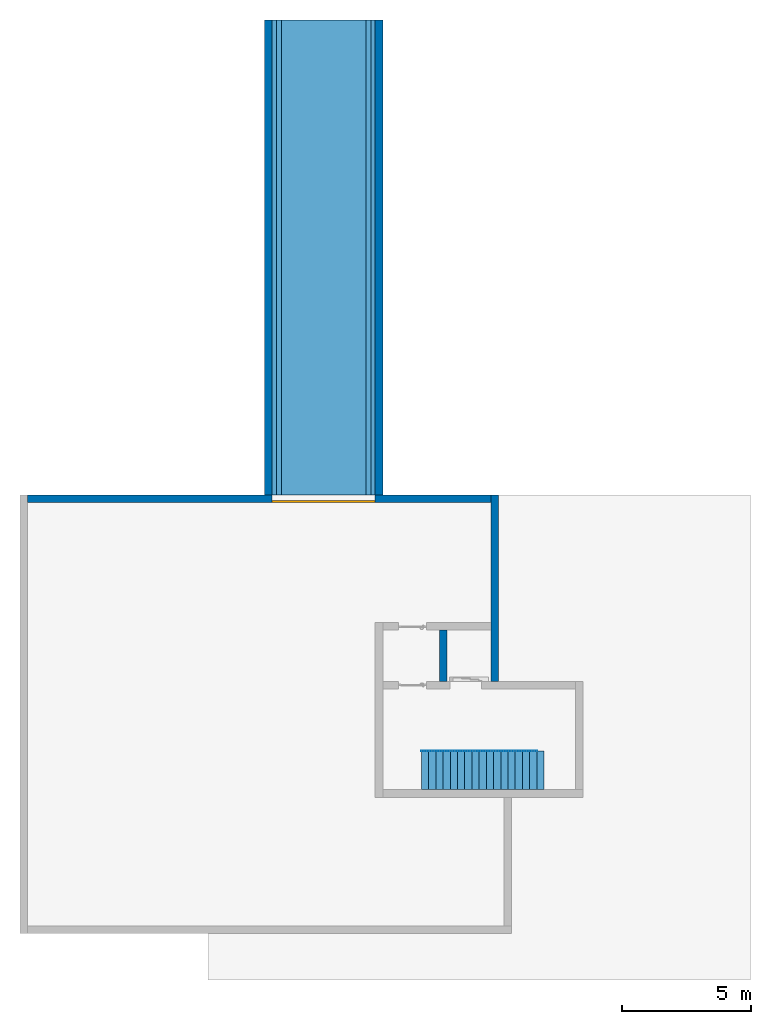
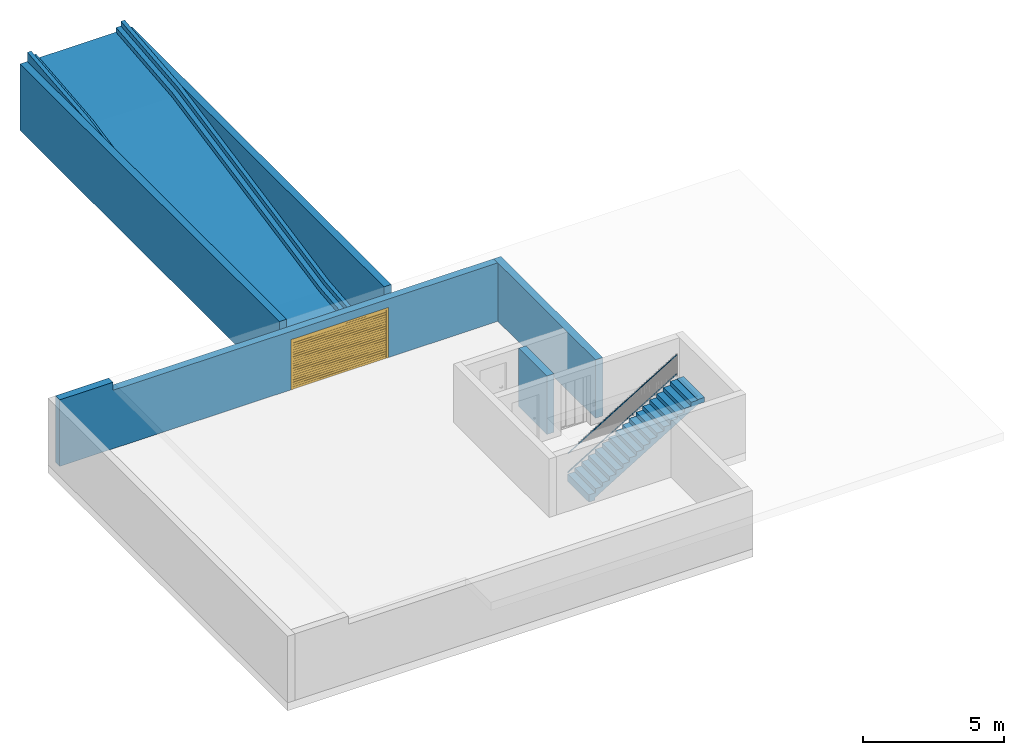
# One storey, part 5 of 6: 5 walls, 3 building element parts, 1 door, 1 ramp, 1 opening, 2 elements without a shape of their own.
"""IFC4 building model written with IfcOpenShell, lengths in metres."""

from ifc_helpers import new_model, entity, si_unit, converted_unit, derived_unit, direction, frame, origin_with_axes, place, context, subcontext, project, spatial, polygons, material, type_object, element, fill, aggregate, save


model = new_model("IFC4")

# Units and contexts
model_context = context("Model", 3, precision=1e-05, world=origin_with_axes(), true_north=direction((0.0, 1.0)))
body_context = subcontext(model_context, "Body", "Model", "MODEL_VIEW")
ifc_project = project(units=[si_unit("LENGTHUNIT", "METRE"), si_unit("AREAUNIT", "SQUARE_METRE"), si_unit("VOLUMEUNIT", "CUBIC_METRE"), converted_unit("PLANEANGLEUNIT", "DEGREE", entity("IfcPlaneAngleMeasure", 0.0174532925199), si_unit("PLANEANGLEUNIT", "RADIAN"), dimensions=[0, 0, 0, 0, 0, 0, 0]), converted_unit("TIMEUNIT", "Year", entity("IfcTimeMeasure", 31556926.0), si_unit("TIMEUNIT", "SECOND"), dimensions=[0, 0, 1, 0, 0, 0, 0]), si_unit("MASSUNIT", "GRAM", prefix="KILO"), si_unit("THERMODYNAMICTEMPERATUREUNIT", "DEGREE_CELSIUS"), si_unit("LUMINOUSINTENSITYUNIT", "LUMEN"), si_unit("ENERGYUNIT", "JOULE", prefix="MEGA"), derived_unit("THERMALCONDUCTANCEUNIT", [(si_unit("POWERUNIT", "WATT"), 1), (si_unit("LENGTHUNIT", "METRE"), -1), (si_unit("THERMODYNAMICTEMPERATUREUNIT", "KELVIN"), -1)]), derived_unit("SPECIFICHEATCAPACITYUNIT", [(si_unit("ENERGYUNIT", "JOULE"), 1), (si_unit("MASSUNIT", "GRAM", prefix="KILO"), -1), (si_unit("THERMODYNAMICTEMPERATUREUNIT", "KELVIN"), -1)]), derived_unit("MASSDENSITYUNIT", [(si_unit("MASSUNIT", "GRAM", prefix="KILO"), 1), (si_unit("VOLUMEUNIT", "CUBIC_METRE"), -1)])], contexts=[model_context])

# Site, building, storey
site_placement = place(None, origin_with_axes())
site = spatial("IfcSite", under=ifc_project, at=site_placement, CompositionType="ELEMENT")
building_placement = place(site_placement, origin_with_axes())
building = spatial("IfcBuilding", under=site, at=building_placement, CompositionType="ELEMENT")
storey_placement = place(building_placement, frame((0.0, 0.0, -2.89), z_axis=(0.0, 0.0, 1.0), x_axis=(1.0, 0.0, 0.0)))
storey = spatial("IfcBuildingStorey", under=building, at=storey_placement, Name="-1. Geschoss", CompositionType="ELEMENT", Elevation=-2.89)

# Walls
ifc_material_1 = material()
wall_type = type_object("IfcWallType", Name="300", PredefinedType="NOTDEFINED")
wall_1_placement = place(storey_placement, frame((-9.2421993804, 8.92118776896, 0.0), z_axis=(0.0, 0.0, 1.0), x_axis=(0.0, 1.0, 0.0)))
element("IfcWall", 1, at=wall_1_placement, inside=storey, type_object=wall_type, material=ifc_material_1, Name="Wand-001", PredefinedType="NOTDEFINED", context=body_context, shape_type="Tessellation", body=[
    polygons([(0.0, 0.0, 0.0), (0.0, 0.3, 0.0), (18.45, 0.3, 0.0), (18.45, 0.0, 0.0), (0.0, 0.0, 2.89), (0.0, 0.3, 2.89), (18.45, 0.3, 2.89), (18.45, 0.0, 2.89)], [[[1, 2, 3, 4]], [[5, 6, 2, 1]], [[2, 6, 7, 3]], [[8, 4, 3, 7]], [[5, 1, 4, 8]], [[6, 5, 8, 7]]], closed=True),
])
wall_2_placement = place(storey_placement, frame((-2.7421993804, 1.37118776896, 0.0), z_axis=(0.0, 0.0, 1.0), x_axis=(0.0, 1.0, 0.0)))
element("IfcWall", 2, at=wall_2_placement, inside=storey, type_object=wall_type, material=ifc_material_1, Name="Wand-001", PredefinedType="NOTDEFINED", context=body_context, shape_type="Tessellation", body=[
    polygons([(2.3, 0.0, 0.0), (2.3, 0.0, 2.54), (2.3, -0.3, 2.54), (2.3, -0.3, 0.0), (0.3, 0.0, 0.0), (0.3, 0.0, 2.54), (0.3, -0.3, 2.54), (0.3, -0.3, 0.0)], [[[1, 2, 3, 4]], [[5, 6, 2, 1]], [[6, 7, 3, 2]], [[4, 3, 7, 8]], [[5, 1, 4, 8]], [[8, 7, 6, 5]]], closed=True),
])
wall_3_placement = place(storey_placement, frame((-0.742199380397, 1.37118776896, 0.0), z_axis=(0.0, 0.0, 1.0), x_axis=(0.0, 1.0, 0.0)))
element("IfcWall", 3, at=wall_3_placement, inside=storey, type_object=wall_type, material=ifc_material_1, Name="Wand-001", PredefinedType="NOTDEFINED", context=body_context, shape_type="Tessellation", body=[
    polygons([(7.55, 0.0, 0.0), (7.55, 0.0, 2.54), (7.55, -0.3, 2.54), (7.55, -0.3, 0.0), (0.3, 0.0, 0.0), (0.3, 0.0, 2.54), (0.3, -0.3, 2.54), (0.3, -0.3, 0.0)], [[[1, 2, 3, 4]], [[5, 6, 2, 1]], [[6, 7, 3, 2]], [[4, 3, 7, 8]], [[5, 1, 4, 8]], [[8, 7, 6, 5]]], closed=True),
])
wall_4_placement = place(storey_placement, frame((-5.2421993804, 8.92118776896, 0.0), z_axis=(0.0, 0.0, 1.0), x_axis=(0.0, 1.0, 0.0)))
element("IfcWall", 4, at=wall_4_placement, inside=storey, type_object=wall_type, material=ifc_material_1, Name="Wand-001", PredefinedType="NOTDEFINED", context=body_context, shape_type="Tessellation", body=[
    polygons([(0.0, 0.0, 2.89), (0.0, -0.3, 2.89), (18.45, -0.3, 2.89), (18.45, 0.0, 2.89), (0.0, 0.0, 0.0), (0.0, -0.3, 0.0), (18.45, -0.3, 0.0), (18.45, 0.0, 0.0)], [[[1, 2, 3, 4]], [[5, 6, 2, 1]], [[2, 6, 7, 3]], [[8, 4, 3, 7]], [[5, 1, 4, 8]], [[6, 5, 8, 7]]], closed=True),
])

# Wall, opening, door
wall_5_placement = place(storey_placement, frame((-19.0421993804, 8.92118776896, 0.0), z_axis=(0.0, 0.0, 1.0), x_axis=(1.0, 0.0, 0.0)))
wall_5 = element("IfcWall", 5, at=wall_5_placement, inside=storey, type_object=wall_type, material=ifc_material_1, Name="Wand-001", PredefinedType="NOTDEFINED", context=body_context, shape_type="Tessellation", body=[
    polygons([(9.8, 0.0, 2.18), (9.8, 0.0, 0.0), (0.3, 0.0, 0.0), (0.3, 0.0, 2.89), (2.5, 0.0, 2.89), (2.5, 0.0, 2.54), (18.3, 0.0, 2.54), (18.3, 0.0, 0.0), (13.8, 0.0, 0.0), (13.8, 0.0, 2.18), (9.8, -0.3, 2.18), (9.8, -0.3, 0.0), (0.3, -0.3, 0.0), (0.3, -0.3, 2.89), (2.5, -0.3, 2.89), (2.5, -0.3, 2.54), (18.3, -0.3, 2.54), (18.3, -0.3, 0.0), (13.8, -0.3, 0.0), (13.8, -0.3, 2.18)], [[[1, 2, 3, 4, 5, 6, 7, 8, 9, 10]], [[2, 1, 11, 12]], [[2, 12, 13, 3]], [[13, 14, 4, 3]], [[15, 5, 4, 14]], [[6, 5, 15, 16]], [[17, 7, 6, 16]], [[7, 17, 18, 8]], [[19, 9, 8, 18]], [[10, 9, 19, 20]], [[1, 10, 20, 11]], [[20, 19, 18, 17, 16, 15, 14, 13, 12, 11]]], closed=True),
])
opening_placement = place(wall_5_placement, frame((11.8, 0.0, 0.0), z_axis=(0.0, 0.0, 1.0), x_axis=(1.0, 0.0, 0.0)))
opening = element("IfcOpeningElement", 6, at=opening_placement, cuts=wall_5, context=body_context, identifier="Reference", shape_type="Tessellation", body=[
    polygons([(2.0, 0.00100000000001, 2.18), (2.0, 0.00100000000001, 0.0), (-2.0, 0.00100000000001, 0.0), (-2.0, 0.00100000000001, 2.18), (2.0, -0.301, 2.18), (2.0, -0.301, 0.0), (-2.0, -0.301, 0.0), (-2.0, -0.301, 2.18)], [[[1, 2, 3, 4]], [[5, 6, 2, 1]], [[6, 7, 3, 2]], [[7, 8, 4, 3]], [[8, 5, 1, 4]], [[7, 6, 5, 8]]], closed=True),
])
door_type = type_object("IfcDoorType", Name="26", OperationType="ROLLINGUP", PredefinedType="DOOR")
door_placement = place(opening_placement, frame((1.92, 0.0, 0.0), z_axis=(0.0, 0.0, 1.0), x_axis=(-1.0, 0.0, 0.0)))
door = element("IfcDoor", 7, at=door_placement, inside=storey, type_object=door_type, OverallHeight=2.18, OverallWidth=4.0, PredefinedType="DOOR", context=body_context, shape_type="Tessellation", body=[
    polygons([(-0.08, 0.3, 0.0), (-0.08, 0.22, 0.0), (-0.08, 0.22, 2.18), (-0.08, 0.3, 2.18), (0.0, 0.3, 0.0), (0.0, 0.22, 0.0), (0.0, 0.22, 2.1), (3.84, 0.22, 2.1), (3.84, 0.22, 0.0), (3.92, 0.22, 0.0), (3.92, 0.22, 2.18), (3.92, 0.3, 2.18), (3.92, 0.3, 0.0), (3.84, 0.3, 0.0), (3.84, 0.3, 2.1), (0.0, 0.3, 2.1)], [[[1, 2, 3, 4]], [[5, 6, 2, 1]], [[2, 6, 7, 8, 9, 10, 11, 3]], [[4, 3, 11, 12]], [[1, 4, 12, 13, 14, 15, 16, 5]], [[16, 7, 6, 5]], [[15, 8, 7, 16]], [[14, 9, 8, 15]], [[13, 10, 9, 14]], [[12, 11, 10, 13]]], closed=True),
    polygons([(-0.08, 0.3, 2.18), (-0.08, 0.22, 2.18), (3.92, 0.22, 2.18), (3.92, 0.3, 2.18)], [[[1, 2, 3, 4]]], closed=False),
    polygons([(0.0, 0.29, 0.0), (0.0, 0.27, 0.0), (0.0, 0.27, 0.09), (0.0, 0.29, 0.09), (3.84, 0.29, 0.0), (3.84, 0.27, 0.0), (3.84, 0.27, 0.09), (3.84, 0.29, 0.09)], [[[1, 2, 3, 4]], [[5, 6, 2, 1]], [[2, 6, 7, 3]], [[4, 3, 7, 8]], [[1, 4, 8, 5]], [[8, 7, 6, 5]]], closed=True),
    polygons([(0.0, 0.29, 0.1), (0.0, 0.27, 0.1), (0.0, 0.27, 0.19), (0.0, 0.29, 0.19), (3.84, 0.29, 0.1), (3.84, 0.27, 0.1), (3.84, 0.27, 0.19), (3.84, 0.29, 0.19)], [[[1, 2, 3, 4]], [[5, 6, 2, 1]], [[2, 6, 7, 3]], [[4, 3, 7, 8]], [[1, 4, 8, 5]], [[8, 7, 6, 5]]], closed=True),
    polygons([(0.0, 0.29, 0.2), (0.0, 0.27, 0.2), (0.0, 0.27, 0.29), (0.0, 0.29, 0.29), (3.84, 0.29, 0.2), (3.84, 0.27, 0.2), (3.84, 0.27, 0.29), (3.84, 0.29, 0.29)], [[[1, 2, 3, 4]], [[5, 6, 2, 1]], [[2, 6, 7, 3]], [[4, 3, 7, 8]], [[1, 4, 8, 5]], [[8, 7, 6, 5]]], closed=True),
    polygons([(0.0, 0.29, 0.3), (0.0, 0.27, 0.3), (0.0, 0.27, 0.39), (0.0, 0.29, 0.39), (3.84, 0.29, 0.3), (3.84, 0.27, 0.3), (3.84, 0.27, 0.39), (3.84, 0.29, 0.39)], [[[1, 2, 3, 4]], [[5, 6, 2, 1]], [[2, 6, 7, 3]], [[4, 3, 7, 8]], [[1, 4, 8, 5]], [[8, 7, 6, 5]]], closed=True),
    polygons([(0.0, 0.29, 0.4), (0.0, 0.27, 0.4), (0.0, 0.27, 0.49), (0.0, 0.29, 0.49), (3.84, 0.29, 0.4), (3.84, 0.27, 0.4), (3.84, 0.27, 0.49), (3.84, 0.29, 0.49)], [[[1, 2, 3, 4]], [[5, 6, 2, 1]], [[2, 6, 7, 3]], [[4, 3, 7, 8]], [[1, 4, 8, 5]], [[8, 7, 6, 5]]], closed=True),
    polygons([(0.0, 0.29, 0.5), (0.0, 0.27, 0.5), (0.0, 0.27, 0.59), (0.0, 0.29, 0.59), (3.84, 0.29, 0.5), (3.84, 0.27, 0.5), (3.84, 0.27, 0.59), (3.84, 0.29, 0.59)], [[[1, 2, 3, 4]], [[5, 6, 2, 1]], [[2, 6, 7, 3]], [[4, 3, 7, 8]], [[1, 4, 8, 5]], [[8, 7, 6, 5]]], closed=True),
    polygons([(0.0, 0.29, 0.6), (0.0, 0.27, 0.6), (0.0, 0.27, 0.69), (0.0, 0.29, 0.69), (3.84, 0.29, 0.6), (3.84, 0.27, 0.6), (3.84, 0.27, 0.69), (3.84, 0.29, 0.69)], [[[1, 2, 3, 4]], [[5, 6, 2, 1]], [[2, 6, 7, 3]], [[4, 3, 7, 8]], [[1, 4, 8, 5]], [[8, 7, 6, 5]]], closed=True),
    polygons([(0.0, 0.29, 0.7), (0.0, 0.27, 0.7), (0.0, 0.27, 0.79), (0.0, 0.29, 0.79), (3.84, 0.29, 0.7), (3.84, 0.27, 0.7), (3.84, 0.27, 0.79), (3.84, 0.29, 0.79)], [[[1, 2, 3, 4]], [[5, 6, 2, 1]], [[2, 6, 7, 3]], [[4, 3, 7, 8]], [[1, 4, 8, 5]], [[8, 7, 6, 5]]], closed=True),
    polygons([(0.0, 0.29, 0.8), (0.0, 0.27, 0.8), (0.0, 0.27, 0.89), (0.0, 0.29, 0.89), (3.84, 0.29, 0.8), (3.84, 0.27, 0.8), (3.84, 0.27, 0.89), (3.84, 0.29, 0.89)], [[[1, 2, 3, 4]], [[5, 6, 2, 1]], [[2, 6, 7, 3]], [[4, 3, 7, 8]], [[1, 4, 8, 5]], [[8, 7, 6, 5]]], closed=True),
    polygons([(0.0, 0.29, 0.9), (0.0, 0.27, 0.9), (0.0, 0.27, 0.99), (0.0, 0.29, 0.99), (3.84, 0.29, 0.9), (3.84, 0.27, 0.9), (3.84, 0.27, 0.99), (3.84, 0.29, 0.99)], [[[1, 2, 3, 4]], [[5, 6, 2, 1]], [[2, 6, 7, 3]], [[4, 3, 7, 8]], [[1, 4, 8, 5]], [[8, 7, 6, 5]]], closed=True),
    polygons([(0.0, 0.29, 1.0), (0.0, 0.27, 1.0), (0.0, 0.27, 1.09), (0.0, 0.29, 1.09), (3.84, 0.29, 1.0), (3.84, 0.27, 1.0), (3.84, 0.27, 1.09), (3.84, 0.29, 1.09)], [[[1, 2, 3, 4]], [[5, 6, 2, 1]], [[2, 6, 7, 3]], [[4, 3, 7, 8]], [[1, 4, 8, 5]], [[8, 7, 6, 5]]], closed=True),
    polygons([(0.0, 0.29, 1.1), (0.0, 0.27, 1.1), (0.0, 0.27, 1.19), (0.0, 0.29, 1.19), (3.84, 0.29, 1.1), (3.84, 0.27, 1.1), (3.84, 0.27, 1.19), (3.84, 0.29, 1.19)], [[[1, 2, 3, 4]], [[5, 6, 2, 1]], [[2, 6, 7, 3]], [[4, 3, 7, 8]], [[1, 4, 8, 5]], [[8, 7, 6, 5]]], closed=True),
    polygons([(0.0, 0.29, 1.2), (0.0, 0.27, 1.2), (0.0, 0.27, 1.29), (0.0, 0.29, 1.29), (3.84, 0.29, 1.2), (3.84, 0.27, 1.2), (3.84, 0.27, 1.29), (3.84, 0.29, 1.29)], [[[1, 2, 3, 4]], [[5, 6, 2, 1]], [[2, 6, 7, 3]], [[4, 3, 7, 8]], [[1, 4, 8, 5]], [[8, 7, 6, 5]]], closed=True),
    polygons([(0.0, 0.29, 1.3), (0.0, 0.27, 1.3), (0.0, 0.27, 1.39), (0.0, 0.29, 1.39), (3.84, 0.29, 1.3), (3.84, 0.27, 1.3), (3.84, 0.27, 1.39), (3.84, 0.29, 1.39)], [[[1, 2, 3, 4]], [[5, 6, 2, 1]], [[2, 6, 7, 3]], [[4, 3, 7, 8]], [[1, 4, 8, 5]], [[8, 7, 6, 5]]], closed=True),
    polygons([(0.0, 0.29, 1.4), (0.0, 0.27, 1.4), (0.0, 0.27, 1.49), (0.0, 0.29, 1.49), (3.84, 0.29, 1.4), (3.84, 0.27, 1.4), (3.84, 0.27, 1.49), (3.84, 0.29, 1.49)], [[[1, 2, 3, 4]], [[5, 6, 2, 1]], [[2, 6, 7, 3]], [[4, 3, 7, 8]], [[1, 4, 8, 5]], [[8, 7, 6, 5]]], closed=True),
    polygons([(0.0, 0.29, 1.5), (0.0, 0.27, 1.5), (0.0, 0.27, 1.59), (0.0, 0.29, 1.59), (3.84, 0.29, 1.5), (3.84, 0.27, 1.5), (3.84, 0.27, 1.59), (3.84, 0.29, 1.59)], [[[1, 2, 3, 4]], [[5, 6, 2, 1]], [[2, 6, 7, 3]], [[4, 3, 7, 8]], [[1, 4, 8, 5]], [[8, 7, 6, 5]]], closed=True),
    polygons([(0.0, 0.29, 1.6), (0.0, 0.27, 1.6), (0.0, 0.27, 1.69), (0.0, 0.29, 1.69), (3.84, 0.29, 1.6), (3.84, 0.27, 1.6), (3.84, 0.27, 1.69), (3.84, 0.29, 1.69)], [[[1, 2, 3, 4]], [[5, 6, 2, 1]], [[2, 6, 7, 3]], [[4, 3, 7, 8]], [[1, 4, 8, 5]], [[8, 7, 6, 5]]], closed=True),
    polygons([(0.0, 0.29, 1.7), (0.0, 0.27, 1.7), (0.0, 0.27, 1.79), (0.0, 0.29, 1.79), (3.84, 0.29, 1.7), (3.84, 0.27, 1.7), (3.84, 0.27, 1.79), (3.84, 0.29, 1.79)], [[[1, 2, 3, 4]], [[5, 6, 2, 1]], [[2, 6, 7, 3]], [[4, 3, 7, 8]], [[1, 4, 8, 5]], [[8, 7, 6, 5]]], closed=True),
    polygons([(0.0, 0.29, 1.8), (0.0, 0.27, 1.8), (0.0, 0.27, 1.89), (0.0, 0.29, 1.89), (3.84, 0.29, 1.8), (3.84, 0.27, 1.8), (3.84, 0.27, 1.89), (3.84, 0.29, 1.89)], [[[1, 2, 3, 4]], [[5, 6, 2, 1]], [[2, 6, 7, 3]], [[4, 3, 7, 8]], [[1, 4, 8, 5]], [[8, 7, 6, 5]]], closed=True),
    polygons([(0.0, 0.29, 1.9), (0.0, 0.27, 1.9), (0.0, 0.27, 1.99), (0.0, 0.29, 1.99), (3.84, 0.29, 1.9), (3.84, 0.27, 1.9), (3.84, 0.27, 1.99), (3.84, 0.29, 1.99)], [[[1, 2, 3, 4]], [[5, 6, 2, 1]], [[2, 6, 7, 3]], [[4, 3, 7, 8]], [[1, 4, 8, 5]], [[8, 7, 6, 5]]], closed=True),
    polygons([(0.0, 0.29, 2.0), (0.0, 0.27, 2.0), (0.0, 0.27, 2.09), (0.0, 0.29, 2.09), (3.84, 0.29, 2.0), (3.84, 0.27, 2.0), (3.84, 0.27, 2.09), (3.84, 0.29, 2.09)], [[[1, 2, 3, 4]], [[5, 6, 2, 1]], [[2, 6, 7, 3]], [[4, 3, 7, 8]], [[1, 4, 8, 5]], [[8, 7, 6, 5]]], closed=True),
    polygons([(3.84, 0.27, 0.0), (3.84, 0.23, 0.0), (0.0, 0.23, 0.0), (0.0, 0.27, 0.0), (3.84, 0.27, 2.1), (3.84, 0.23, 2.1), (0.0, 0.23, 2.1), (0.0, 0.27, 2.1)], [[[1, 2, 3, 4]], [[5, 6, 2, 1]], [[2, 6, 7, 3]], [[4, 3, 7, 8]], [[1, 4, 8, 5]], [[8, 7, 6, 5]]], closed=True),
])
fill(opening, door)

# Ramp
ifc_material_2 = material(Name="Stahlbeton")
ramp_type = type_object("IfcRampType", Name="Rampe 26", PredefinedType="NOTDEFINED")
ramp_placement = place(storey_placement, frame((-7.2421993804, 8.92118776896, 0.0), z_axis=(0.0, 0.0, 1.0), x_axis=(0.0, 1.0, 0.0)))
element("IfcRamp", 8, at=ramp_placement, inside=storey, type_object=ramp_type, material=ifc_material_2, Name="0002", PredefinedType="NOTDEFINED", context=body_context, shape_type="Tessellation", body=[
    polygons([(0.0, 2.0, -0.200997512422), (0.0, 2.0, 0.0), (4.0, 2.0, 0.4), (14.45, 2.0, 2.49), (18.45, 2.0, 2.89), (18.45, 2.0, 2.68900248758), (14.4796326812, 2.0, 2.2919657557), (4.02963268121, 2.0, 0.201965755699), (0.0, -2.0, -0.200997512422), (0.0, -2.0, 0.0), (4.0, -2.0, 0.4), (14.45, -2.0, 2.49), (18.45, -2.0, 2.89), (18.45, -2.0, 2.68900248758), (14.4796326812, -2.0, 2.2919657557), (4.02963268121, -2.0, 0.201965755699)], [[[1, 2, 3, 4, 5, 6, 7, 8]], [[1, 9, 10, 2]], [[2, 10, 11, 3]], [[3, 11, 12, 4]], [[4, 12, 13, 5]], [[6, 5, 13, 14]], [[15, 7, 6, 14]], [[16, 8, 7, 15]], [[9, 1, 8, 16]], [[10, 9, 16, 15, 14, 13, 12, 11]]], closed=True),
    polygons([(0.0, -1.64, 0.0), (0.0, -1.64, 0.200997512422), (3.97036731879, -1.64, 0.598034244301), (14.4203673188, -1.64, 2.6880342443), (18.45, -1.64, 3.09099751242), (18.45, -1.64, 2.89), (14.45, -1.64, 2.49), (4.0, -1.64, 0.4), (0.0, -1.84, 0.0), (0.0, -1.84, 0.200997512422), (3.97036731879, -1.84, 0.598034244301), (14.4203673188, -1.84, 2.6880342443), (18.45, -1.84, 3.09099751242), (18.45, -1.84, 2.89), (14.45, -1.84, 2.49), (4.0, -1.84, 0.4)], [[[1, 2, 3, 4, 5, 6, 7, 8]], [[1, 9, 10, 2]], [[2, 10, 11, 3]], [[3, 11, 12, 4]], [[4, 12, 13, 5]], [[6, 5, 13, 14]], [[15, 7, 6, 14]], [[16, 8, 7, 15]], [[9, 1, 8, 16]], [[10, 9, 16, 15, 14, 13, 12, 11]]], closed=True),
    polygons([(0.0, 1.84, 0.0), (0.0, 1.84, 0.200997512422), (3.97036731879, 1.84, 0.598034244301), (14.4203673188, 1.84, 2.6880342443), (18.45, 1.84, 3.09099751242), (18.45, 1.84, 2.89), (14.45, 1.84, 2.49), (4.0, 1.84, 0.4), (0.0, 1.64, 0.0), (0.0, 1.64, 0.200997512422), (3.97036731879, 1.64, 0.598034244301), (14.4203673188, 1.64, 2.6880342443), (18.45, 1.64, 3.09099751242), (18.45, 1.64, 2.89), (14.45, 1.64, 2.49), (4.0, 1.64, 0.4)], [[[1, 2, 3, 4, 5, 6, 7, 8]], [[1, 9, 10, 2]], [[2, 10, 11, 3]], [[3, 11, 12, 4]], [[4, 12, 13, 5]], [[6, 5, 13, 14]], [[15, 7, 6, 14]], [[16, 8, 7, 15]], [[9, 1, 8, 16]], [[10, 9, 16, 15, 14, 13, 12, 11]]], closed=True),
    polygons([(0.0, -1.84, 0.0), (0.0, -1.84, 0.401995024845), (3.94073463757, -1.84, 0.796068488602), (14.3907346376, -1.84, 2.8860684886), (18.45, -1.84, 3.29199502484), (18.45, -1.84, 2.89), (14.45, -1.84, 2.49), (4.0, -1.84, 0.4), (0.0, -2.0, 0.0), (0.0, -2.0, 0.401995024845), (3.94073463757, -2.0, 0.796068488602), (14.3907346376, -2.0, 2.8860684886), (18.45, -2.0, 3.29199502484), (18.45, -2.0, 2.89), (14.45, -2.0, 2.49), (4.0, -2.0, 0.4)], [[[1, 2, 3, 4, 5, 6, 7, 8]], [[1, 9, 10, 2]], [[2, 10, 11, 3]], [[3, 11, 12, 4]], [[4, 12, 13, 5]], [[6, 5, 13, 14]], [[15, 7, 6, 14]], [[16, 8, 7, 15]], [[9, 1, 8, 16]], [[10, 9, 16, 15, 14, 13, 12, 11]]], closed=True),
    polygons([(0.0, 2.0, 0.0), (0.0, 2.0, 0.401995024845), (3.94073463757, 2.0, 0.796068488602), (14.3907346376, 2.0, 2.8860684886), (18.45, 2.0, 3.29199502484), (18.45, 2.0, 2.89), (14.45, 2.0, 2.49), (4.0, 2.0, 0.4), (0.0, 1.84, 0.0), (0.0, 1.84, 0.401995024845), (3.94073463757, 1.84, 0.796068488602), (14.3907346376, 1.84, 2.8860684886), (18.45, 1.84, 3.29199502484), (18.45, 1.84, 2.89), (14.45, 1.84, 2.49), (4.0, 1.84, 0.4)], [[[1, 2, 3, 4, 5, 6, 7, 8]], [[1, 9, 10, 2]], [[2, 10, 11, 3]], [[3, 11, 12, 4]], [[4, 12, 13, 5]], [[6, 5, 13, 14]], [[15, 7, 6, 14]], [[16, 8, 7, 15]], [[9, 1, 8, 16]], [[10, 9, 16, 15, 14, 13, 12, 11]]], closed=True),
])

# Space
space_placement = place(storey_placement, frame((-4.9421993804, -2.52881223104, 0.0), z_axis=(0.0, 0.0, 1.0), x_axis=(1.0, 0.0, 0.0)))
space = spatial("IfcSpace", under=storey, at=space_placement, CompositionType="ELEMENT", PredefinedType="INTERNAL")

# Railing, building element parts
railing_type = type_object("IfcRailingType", PredefinedType="NOTDEFINED")
railing_placement = place(space_placement, frame((1.5, 1.5, 0.17), z_axis=(0.0, 0.0, 1.0), x_axis=(1.0, 0.0, 0.0)))
railing = element("IfcRailing", 9, at=railing_placement, inside=space, type_object=railing_type, PredefinedType="NOTDEFINED")
ifc_material_3 = material()
building_element_part_1_placement = place(railing_placement, origin_with_axes())
building_element_part_1 = element("IfcBuildingElementPart", 10, at=building_element_part_1_placement, material=ifc_material_3, PredefinedType="NOTDEFINED", context=body_context, shape_type="Tessellation", body=[
    polygons([(0.0, -0.0125, 0.9), (0.012974453356, -0.0125, 0.878630312119), (4.49297445336, -0.0125, 3.59863031212), (4.48, -0.0125, 3.62), (0.0, 0.0125, 0.9), (0.012974453356, 0.0125, 0.878630312119), (4.49297445336, 0.0125, 3.59863031212), (4.48, 0.0125, 3.62)], [[[1, 2, 3, 4]], [[1, 5, 6, 2]], [[2, 6, 7, 3]], [[4, 3, 7, 8]], [[5, 1, 4, 8]], [[6, 5, 8, 7]]], closed=True),
])
building_element_part_2_placement = place(railing_placement, origin_with_axes())
building_element_part_2 = element("IfcBuildingElementPart", 11, at=building_element_part_2_placement, material=ifc_material_3, PredefinedType="NOTDEFINED", context=body_context, shape_type="Tessellation", body=[
    polygons([(-0.00648722667802, -0.0125, 0.0806848439403), (0.00648722667802, -0.0125, 0.0593151560597), (4.48648722668, -0.0125, 2.77931515606), (4.47351277332, -0.0125, 2.80068484394), (-0.00648722667802, 0.0125, 0.0806848439403), (0.00648722667802, 0.0125, 0.0593151560597), (4.48648722668, 0.0125, 2.77931515606), (4.47351277332, 0.0125, 2.80068484394)], [[[1, 2, 3, 4]], [[1, 5, 6, 2]], [[2, 6, 7, 3]], [[4, 3, 7, 8]], [[5, 1, 4, 8]], [[6, 5, 8, 7]]], closed=True),
])
aggregate(railing, [building_element_part_1, building_element_part_2])

# Stair, building element part
stair_type = type_object("IfcStairType", PredefinedType="NOTDEFINED")
stair_placement = place(space_placement, frame((1.5, 1.5, 0.0), z_axis=(0.0, 0.0, 1.0), x_axis=(1.0, 0.0, 0.0)))
stair = element("IfcStair", 12, at=stair_placement, inside=space, type_object=stair_type, Name="Treppe - 001", PredefinedType="NOTDEFINED")
building_element_part_3_placement = place(stair_placement, origin_with_axes())
building_element_part_3 = element("IfcBuildingElementPart", 13, at=building_element_part_3_placement, material=ifc_material_1, PredefinedType="NOTDEFINED", context=body_context, shape_type="Tessellation", body=[
    polygons([(4.76, 0.0, 2.74), (4.76, -1.5, 2.74), (4.76, -1.5, 2.69112016499), (4.76, 0.0, 2.69112016499), (4.48, 0.0, 2.74), (4.48, -1.5, 2.74), (4.51109619885, -1.5, 2.54), (4.76, -1.5, 2.54), (4.48, -1.5, 2.72), (4.2, -1.5, 2.72), (4.2, -1.5, 2.55), (3.92, -1.5, 2.55), (3.92, -1.5, 2.38), (3.64, -1.5, 2.38), (3.64, -1.5, 2.21), (3.36, -1.5, 2.21), (3.36, -1.5, 2.04), (3.08, -1.5, 2.04), (3.08, -1.5, 1.87), (2.8, -1.5, 1.87), (2.8, -1.5, 1.7), (2.52, -1.5, 1.7), (2.52, -1.5, 1.53), (2.24, -1.5, 1.53), (2.24, -1.5, 1.36), (1.96, -1.5, 1.36), (1.96, -1.5, 1.19), (1.68, -1.5, 1.19), (1.68, -1.5, 1.02), (1.4, -1.5, 1.02), (1.4, -1.5, 0.85), (1.12, -1.5, 0.85), (1.12, -1.5, 0.68), (0.84, -1.5, 0.68), (0.84, -1.5, 0.51), (0.56, -1.5, 0.51), (0.56, -1.5, 0.34), (0.28, -1.5, 0.34), (0.28, -1.5, 0.17), (0.0, -1.5, 0.17), (0.0, -1.5, -0.15), (0.25, -1.5, -0.15), (0.25, -1.5, -0.0470941207291), (0.28, -1.5, -0.0288798350148), (0.373333333333, -1.5, 0.0277868316519), (0.466666666667, -1.5, 0.0844534983185), (0.56, -1.5, 0.141120164985), (0.653333333333, -1.5, 0.197786831652), (0.746666666667, -1.5, 0.254453498319), (0.84, -1.5, 0.311120164985), (0.933333333333, -1.5, 0.367786831652), (1.02666666667, -1.5, 0.424453498319), (1.12, -1.5, 0.481120164985), (1.21333333333, -1.5, 0.537786831652), (1.30666666667, -1.5, 0.594453498319), (1.4, -1.5, 0.651120164985), (1.49333333333, -1.5, 0.707786831652), (1.58666666667, -1.5, 0.764453498319), (1.68, -1.5, 0.821120164985), (1.77333333333, -1.5, 0.877786831652), (1.86666666667, -1.5, 0.934453498319), (1.96, -1.5, 0.991120164985), (2.05333333333, -1.5, 1.04778683165), (2.14666666667, -1.5, 1.10445349832), (2.24, -1.5, 1.16112016499), (2.33333333333, -1.5, 1.21778683165), (2.42666666667, -1.5, 1.27445349832), (2.52, -1.5, 1.33112016499), (2.61333333333, -1.5, 1.38778683165), (2.70666666667, -1.5, 1.44445349832), (2.8, -1.5, 1.50112016499), (2.89333333333, -1.5, 1.55778683165), (2.98666666667, -1.5, 1.61445349832), (3.08, -1.5, 1.67112016499), (3.17333333333, -1.5, 1.72778683165), (3.26666666667, -1.5, 1.78445349832), (3.36, -1.5, 1.84112016499), (3.45333333333, -1.5, 1.89778683165), (3.54666666667, -1.5, 1.95445349832), (3.64, -1.5, 2.01112016499), (3.73333333333, -1.5, 2.06778683165), (3.82666666667, -1.5, 2.12445349832), (3.92, -1.5, 2.18112016499), (4.01333333333, -1.5, 2.23778683165), (4.10666666667, -1.5, 2.29445349832), (4.2, -1.5, 2.35112016499), (4.29333333333, -1.5, 2.40778683165), (4.38666666667, -1.5, 2.46445349832), (4.48, -1.5, 2.52112016499), (4.76, 0.0, 2.54), (4.51109619885, 0.0, 2.54), (4.48, 0.0, 2.52112016499), (4.38666666667, 0.0, 2.46445349832), (4.29333333333, 0.0, 2.40778683165), (4.2, 0.0, 2.35112016499), (4.10666666667, 0.0, 2.29445349832), (4.01333333333, 0.0, 2.23778683165), (3.92, 0.0, 2.18112016499), (3.82666666667, 0.0, 2.12445349832), (3.73333333333, 0.0, 2.06778683165), (3.64, 0.0, 2.01112016499), (3.54666666667, 0.0, 1.95445349832), (3.45333333333, 0.0, 1.89778683165), (3.36, 0.0, 1.84112016499), (3.26666666667, 0.0, 1.78445349832), (3.17333333333, 0.0, 1.72778683165), (3.08, 0.0, 1.67112016499), (2.98666666667, 0.0, 1.61445349832), (2.89333333333, 0.0, 1.55778683165), (2.8, 0.0, 1.50112016499), (2.70666666667, 0.0, 1.44445349832), (2.61333333333, 0.0, 1.38778683165), (2.52, 0.0, 1.33112016499), (2.42666666667, 0.0, 1.27445349832), (2.33333333333, 0.0, 1.21778683165), (2.24, 0.0, 1.16112016499), (2.14666666667, 0.0, 1.10445349832), (2.05333333333, 0.0, 1.04778683165), (1.96, 0.0, 0.991120164985), (1.86666666667, 0.0, 0.934453498319), (1.77333333333, 0.0, 0.877786831652), (1.68, 0.0, 0.821120164985), (1.58666666667, 0.0, 0.764453498319), (1.49333333333, 0.0, 0.707786831652), (1.4, 0.0, 0.651120164985), (1.30666666667, 0.0, 0.594453498319), (1.21333333333, 0.0, 0.537786831652), (1.12, 0.0, 0.481120164985), (1.02666666667, 0.0, 0.424453498319), (0.933333333333, 0.0, 0.367786831652), (0.84, 0.0, 0.311120164985), (0.746666666667, 0.0, 0.254453498319), (0.653333333333, 0.0, 0.197786831652), (0.56, 0.0, 0.141120164985), (0.466666666667, 0.0, 0.0844534983185), (0.373333333333, 0.0, 0.0277868316519), (0.28, 0.0, -0.0288798350148), (0.25, 0.0, -0.0470941207291), (0.25, 0.0, -0.15), (0.0, 0.0, -0.15), (0.0, 0.0, 0.17), (0.28, 0.0, 0.17), (0.28, 0.0, 0.34), (0.56, 0.0, 0.34), (0.56, 0.0, 0.51), (0.84, 0.0, 0.51), (0.84, 0.0, 0.68), (1.12, 0.0, 0.68), (1.12, 0.0, 0.85), (1.4, 0.0, 0.85), (1.4, 0.0, 1.02), (1.68, 0.0, 1.02), (1.68, 0.0, 1.19), (1.96, 0.0, 1.19), (1.96, 0.0, 1.36), (2.24, 0.0, 1.36), (2.24, 0.0, 1.53), (2.52, 0.0, 1.53), (2.52, 0.0, 1.7), (2.8, 0.0, 1.7), (2.8, 0.0, 1.87), (3.08, 0.0, 1.87), (3.08, 0.0, 2.04), (3.36, 0.0, 2.04), (3.36, 0.0, 2.21), (3.64, 0.0, 2.21), (3.64, 0.0, 2.38), (3.92, 0.0, 2.38), (3.92, 0.0, 2.55), (4.2, 0.0, 2.55), (4.2, 0.0, 2.72), (4.48, 0.0, 2.72)], [[[1, 2, 3, 4]], [[2, 1, 5, 6]], [[7, 8, 3, 2, 6, 9, 10, 11, 12, 13, 14, 15, 16, 17, 18, 19, 20, 21, 22, 23, 24, 25, 26, 27, 28, 29, 30, 31, 32, 33, 34, 35, 36, 37, 38, 39, 40, 41, 42, 43, 44, 45, 46, 47, 48, 49, 50, 51, 52, 53, 54, 55, 56, 57, 58, 59, 60, 61, 62, 63, 64, 65, 66, 67, 68, 69, 70, 71, 72, 73, 74, 75, 76, 77, 78, 79, 80, 81, 82, 83, 84, 85, 86, 87, 88, 89]], [[8, 90, 4, 3]], [[5, 1, 4, 90, 91, 92, 93, 94, 95, 96, 97, 98, 99, 100, 101, 102, 103, 104, 105, 106, 107, 108, 109, 110, 111, 112, 113, 114, 115, 116, 117, 118, 119, 120, 121, 122, 123, 124, 125, 126, 127, 128, 129, 130, 131, 132, 133, 134, 135, 136, 137, 138, 139, 140, 141, 142, 143, 144, 145, 146, 147, 148, 149, 150, 151, 152, 153, 154, 155, 156, 157, 158, 159, 160, 161, 162, 163, 164, 165, 166, 167, 168, 169, 170, 171, 172]], [[5, 172, 9, 6]], [[90, 8, 7, 91]], [[10, 9, 172, 171]], [[171, 170, 11, 10]], [[12, 11, 170, 169]], [[169, 168, 13, 12]], [[14, 13, 168, 167]], [[167, 166, 15, 14]], [[16, 15, 166, 165]], [[165, 164, 17, 16]], [[18, 17, 164, 163]], [[163, 162, 19, 18]], [[20, 19, 162, 161]], [[161, 160, 21, 20]], [[22, 21, 160, 159]], [[159, 158, 23, 22]], [[24, 23, 158, 157]], [[157, 156, 25, 24]], [[26, 25, 156, 155]], [[155, 154, 27, 26]], [[28, 27, 154, 153]], [[153, 152, 29, 28]], [[30, 29, 152, 151]], [[151, 150, 31, 30]], [[32, 31, 150, 149]], [[149, 148, 33, 32]], [[34, 33, 148, 147]], [[147, 146, 35, 34]], [[36, 35, 146, 145]], [[145, 144, 37, 36]], [[38, 37, 144, 143]], [[143, 142, 39, 38]], [[40, 39, 142, 141]], [[140, 41, 40, 141]], [[41, 140, 139, 42]], [[43, 42, 139, 138]], [[138, 137, 44, 43]], [[137, 136, 45, 44]], [[136, 135, 46, 45]], [[135, 134, 47, 46]], [[134, 133, 48, 47]], [[133, 132, 49, 48]], [[132, 131, 50, 49]], [[131, 130, 51, 50]], [[130, 129, 52, 51]], [[129, 128, 53, 52]], [[128, 127, 54, 53]], [[127, 126, 55, 54]], [[126, 125, 56, 55]], [[125, 124, 57, 56]], [[124, 123, 58, 57]], [[123, 122, 59, 58]], [[122, 121, 60, 59]], [[121, 120, 61, 60]], [[120, 119, 62, 61]], [[119, 118, 63, 62]], [[118, 117, 64, 63]], [[117, 116, 65, 64]], [[116, 115, 66, 65]], [[115, 114, 67, 66]], [[114, 113, 68, 67]], [[113, 112, 69, 68]], [[112, 111, 70, 69]], [[111, 110, 71, 70]], [[110, 109, 72, 71]], [[109, 108, 73, 72]], [[108, 107, 74, 73]], [[107, 106, 75, 74]], [[106, 105, 76, 75]], [[105, 104, 77, 76]], [[104, 103, 78, 77]], [[103, 102, 79, 78]], [[102, 101, 80, 79]], [[101, 100, 81, 80]], [[100, 99, 82, 81]], [[99, 98, 83, 82]], [[98, 97, 84, 83]], [[97, 96, 85, 84]], [[96, 95, 86, 85]], [[95, 94, 87, 86]], [[94, 93, 88, 87]], [[93, 92, 89, 88]], [[89, 92, 91, 7]]], closed=True),
])
aggregate(stair, [building_element_part_3])

save(model, "model.ifc")
